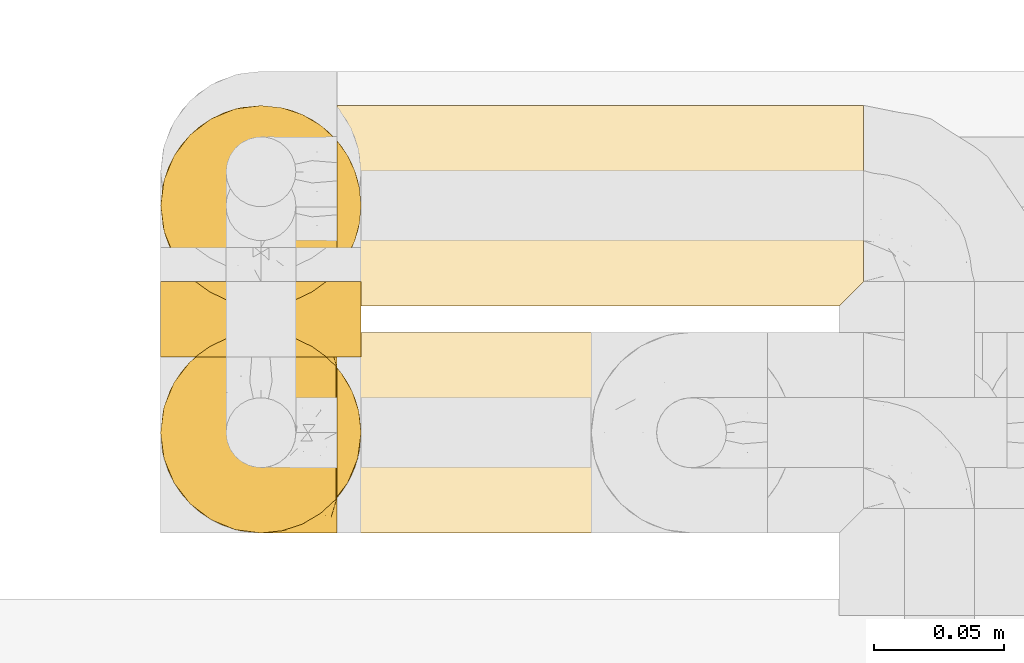
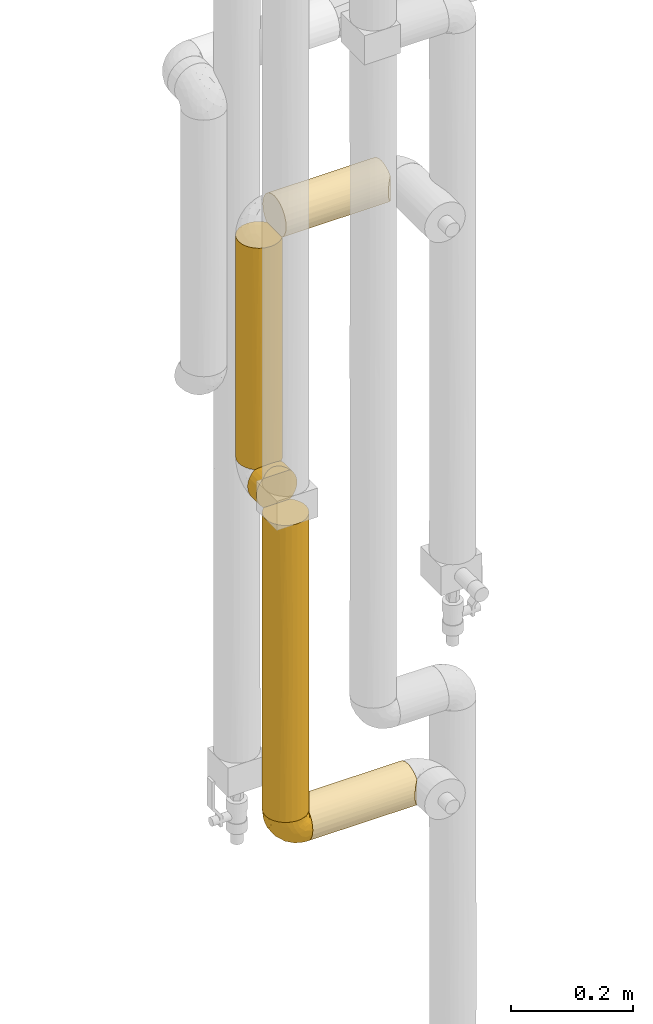
# One storey, part 326 of 827: 6 coverings.
"""IFC2X3 building model written with IfcOpenShell, lengths in millimetres."""

from ifc_helpers import new_model, entity, si_unit, converted_unit, derived_unit, direction, frame, origin, place, context, subcontext, project, spatial, faceted_brep, element, save


model = new_model("IFC2X3")

# Units and contexts
model_context = context("Model", 3, precision=0.01, world=origin(), true_north=direction((6.12303176911189e-17, 1.0)))
body_context = subcontext(model_context, "Body", "Model", "MODEL_VIEW")
ifc_project = project(units=[si_unit("LENGTHUNIT", "METRE", prefix="MILLI"), si_unit("AREAUNIT", "SQUARE_METRE"), si_unit("VOLUMEUNIT", "CUBIC_METRE"), converted_unit("PLANEANGLEUNIT", "DEGREE", entity("IfcRatioMeasure", 0.0174532925199433), si_unit("PLANEANGLEUNIT", "RADIAN"), dimensions=[0, 0, 0, 0, 0, 0, 0]), si_unit("MASSUNIT", "GRAM", prefix="KILO"), derived_unit("MASSDENSITYUNIT", [(si_unit("MASSUNIT", "GRAM", prefix="KILO"), 1), (si_unit("LENGTHUNIT", "METRE"), -3)]), derived_unit("MOMENTOFINERTIAUNIT", [(si_unit("LENGTHUNIT", "METRE"), 4)]), si_unit("TIMEUNIT", "SECOND"), si_unit("FREQUENCYUNIT", "HERTZ"), si_unit("THERMODYNAMICTEMPERATUREUNIT", "DEGREE_CELSIUS"), derived_unit("THERMALTRANSMITTANCEUNIT", [(si_unit("MASSUNIT", "GRAM", prefix="KILO"), 1), (si_unit("THERMODYNAMICTEMPERATUREUNIT", "KELVIN"), -1), (si_unit("TIMEUNIT", "SECOND"), -3)]), derived_unit("VOLUMETRICFLOWRATEUNIT", [(si_unit("LENGTHUNIT", "METRE"), 3), (si_unit("TIMEUNIT", "SECOND"), -1)]), derived_unit("MASSFLOWRATEUNIT", [(si_unit("MASSUNIT", "GRAM", prefix="KILO"), 1), (si_unit("TIMEUNIT", "SECOND"), -1)]), derived_unit("ROTATIONALFREQUENCYUNIT", [(si_unit("TIMEUNIT", "SECOND"), -1)]), si_unit("ELECTRICCURRENTUNIT", "AMPERE"), si_unit("ELECTRICVOLTAGEUNIT", "VOLT"), si_unit("POWERUNIT", "WATT"), si_unit("FORCEUNIT", "NEWTON", prefix="KILO"), si_unit("ILLUMINANCEUNIT", "LUX"), si_unit("LUMINOUSFLUXUNIT", "LUMEN"), si_unit("LUMINOUSINTENSITYUNIT", "CANDELA"), derived_unit("USERDEFINED", [(si_unit("MASSUNIT", "GRAM", prefix="KILO"), -1), (si_unit("LENGTHUNIT", "METRE"), -2), (si_unit("TIMEUNIT", "SECOND"), 3), (si_unit("LUMINOUSFLUXUNIT", "LUMEN"), 1)]), derived_unit("LINEARVELOCITYUNIT", [(si_unit("LENGTHUNIT", "METRE"), 1), (si_unit("TIMEUNIT", "SECOND"), -1)]), si_unit("PRESSUREUNIT", "PASCAL"), derived_unit("USERDEFINED", [(si_unit("LENGTHUNIT", "METRE"), -2), (si_unit("MASSUNIT", "GRAM", prefix="KILO"), 1), (si_unit("TIMEUNIT", "SECOND"), -2)]), derived_unit("LINEARFORCEUNIT", [(si_unit("MASSUNIT", "GRAM", prefix="KILO"), 1), (si_unit("LENGTHUNIT", "METRE"), 1), (si_unit("TIMEUNIT", "SECOND"), -2), (si_unit("LENGTHUNIT", "METRE"), -1)]), derived_unit("PLANARFORCEUNIT", [(si_unit("MASSUNIT", "GRAM", prefix="KILO"), 1), (si_unit("LENGTHUNIT", "METRE"), 1), (si_unit("TIMEUNIT", "SECOND"), -2), (si_unit("LENGTHUNIT", "METRE"), -2)])], contexts=[model_context])

# Site, building, storey
site_placement = place(None, origin())
site = spatial("IfcSite", under=ifc_project, at=site_placement, CompositionType="ELEMENT")
building_placement = place(site_placement, origin())
building = spatial("IfcBuilding", under=site, at=building_placement, CompositionType="ELEMENT")
storey_placement = place(building_placement, frame((0.0, 0.0, 28200.0)))
storey = spatial("IfcBuildingStorey", under=building, at=storey_placement, Name="08", CompositionType="ELEMENT", Elevation=28200.0)

# Coverings
covering_1_placement = place(storey_placement, frame((34485.39, 18294.92, 1087.5)))
element("IfcCovering", 1, at=covering_1_placement, inside=storey, Name=":ADSK_", ObjectType=":ADSK_", PredefinedType="INSULATION", context=body_context, shape_type="Brep", body=[
    faceted_brep([(73.25, 20.8, 593.5), (77.09, 30.06, 593.5), (78.4, 40.0, 593.5), (77.52, 48.16, 593.5), (74.93, 55.94, 593.5), (70.75, 62.99, 593.5), (65.17, 69.0, 593.5), (14.82, 69.0, 593.5), (9.24, 62.99, 593.5), (5.06, 55.94, 593.5), (2.47, 48.16, 593.5), (1.6, 40.0, 593.5), (2.9, 30.06, 593.5), (6.74, 20.8, 593.5), (12.84, 12.84, 593.5), (20.8, 6.74, 593.5), (30.06, 2.9, 593.5), (40.0, 1.6, 593.5), (49.93, 2.9, 593.5), (59.2, 6.74, 593.5), (67.15, 12.84, 593.5), (69.1, 14.94, 1.6), (63.08, 9.31, 1.6), (56.01, 5.09, 1.6), (48.2, 2.48, 1.6), (40.0, 1.6, 1.6), (30.06, 2.9, 1.6), (20.8, 6.74, 1.6), (12.84, 12.84, 1.6), (6.74, 20.8, 1.6), (2.9, 30.06, 1.6), (1.6, 40.0, 1.6), (2.9, 49.93, 1.6), (6.74, 59.2, 1.6), (12.84, 67.15, 1.6), (20.8, 73.25, 1.6), (30.06, 77.09, 1.6), (40.0, 78.4, 1.6), (48.2, 77.51, 1.6), (56.01, 74.9, 1.6), (63.08, 70.68, 1.6), (69.1, 65.05, 1.6), (77.79, 46.78, 10.29), (76.0, 53.36, 8.5), (77.01, 50.2, 296.29), (74.59, 56.67, 378.86), (73.07, 59.51, 5.57), (71.09, 62.53, 290.54), (50.25, 77.0, 298.79), (53.43, 75.97, 586.52), (56.68, 74.58, 392.52), (78.4, 40.0, 302.2), (78.4, 40.0, 227.27), (78.4, 40.0, 10.9), (62.64, 71.01, 304.65), (57.7, 74.07, 194.68), (40.0, 78.4, 292.85), (46.82, 77.78, 584.71), (59.61, 73.01, 589.48), (40.0, 78.4, 367.72), (40.0, 78.4, 584.1), (29.74, 77.0, 301.9), (11.64, 65.89, 381.54), (17.34, 71.0, 292.9), (23.33, 74.59, 205.22), (6.96, 59.58, 309.24), (33.17, 77.78, 584.71), (26.56, 75.97, 586.52), (20.38, 73.01, 589.48), (2.89, 49.87, 299.72), (1.6, 40.0, 377.12), (2.35, 32.42, 385.18), (4.52, 25.3, 339.18), (32.5, 2.33, 374.62), (25.3, 4.52, 297.55), (9.53, 16.62, 297.55), (16.62, 9.53, 339.18), (40.0, 1.6, 297.55), (40.0, 1.6, 217.97), (49.87, 2.89, 295.47), (59.66, 7.01, 285.81), (65.97, 11.72, 213.92), (71.08, 17.45, 301.5), (74.63, 23.42, 391.28), (73.07, 20.48, 5.57), (76.0, 26.63, 8.5), (77.02, 29.79, 293.21), (77.79, 33.21, 10.29)], [[[0, 1, 2, 3, 4, 5, 6, 7, 8, 9, 10, 11, 12, 13, 14, 15, 16, 17, 18, 19, 20]], [[21, 22, 23, 24, 25, 26, 27, 28, 29, 30, 31, 32, 33, 34, 35, 36, 37, 38, 39, 40, 41]], [[42, 43, 44]], [[5, 4, 45]], [[46, 41, 47]], [[48, 49, 50]], [[43, 45, 44]], [[45, 43, 46]], [[3, 51, 44]], [[51, 42, 44]], [[3, 44, 45]], [[42, 51, 52, 53]], [[47, 54, 6]], [[3, 45, 4]], [[51, 3, 2]], [[6, 5, 47]], [[55, 48, 50]], [[56, 38, 37]], [[39, 38, 48]], [[40, 55, 54]], [[48, 55, 39]], [[48, 56, 57]], [[55, 40, 39]], [[58, 6, 54]], [[46, 47, 45]], [[57, 49, 48]], [[38, 56, 48]], [[41, 40, 54]], [[50, 58, 54]], [[58, 50, 49]], [[55, 50, 54]], [[41, 54, 47]], [[57, 56, 59, 60]], [[5, 45, 47]], [[61, 59, 56, 37]], [[61, 37, 36]], [[34, 62, 63]], [[35, 63, 64]], [[34, 65, 62]], [[66, 61, 67]], [[66, 60, 59]], [[64, 67, 61]], [[59, 61, 66]], [[35, 34, 63]], [[63, 7, 68]], [[64, 68, 67]], [[34, 33, 65]], [[36, 64, 61]], [[69, 32, 31]], [[33, 69, 65]], [[68, 64, 63]], [[70, 11, 10]], [[9, 65, 69]], [[8, 65, 9]], [[69, 33, 32]], [[65, 8, 62]], [[70, 10, 69]], [[70, 69, 31]], [[9, 69, 10]], [[7, 63, 62]], [[7, 62, 8]], [[36, 35, 64]], [[71, 30, 72]], [[26, 73, 74]], [[71, 11, 70, 31]], [[72, 75, 13]], [[75, 72, 29]], [[71, 31, 30]], [[28, 75, 29]], [[75, 14, 13]], [[13, 12, 72]], [[27, 74, 76]], [[17, 73, 77]], [[74, 27, 26]], [[74, 15, 76]], [[28, 76, 75]], [[26, 25, 78, 77]], [[14, 75, 76]], [[27, 76, 28]], [[71, 72, 12]], [[15, 14, 76]], [[74, 73, 16]], [[15, 74, 16]], [[29, 72, 30]], [[77, 73, 26]], [[11, 71, 12]], [[73, 17, 16]], [[78, 24, 79]], [[80, 22, 81]], [[21, 81, 22]], [[20, 81, 82]], [[80, 23, 22]], [[83, 84, 85]], [[24, 78, 25]], [[23, 80, 79]], [[17, 79, 18]], [[20, 19, 80]], [[1, 0, 83]], [[82, 81, 21]], [[83, 85, 86]], [[20, 80, 81]], [[87, 86, 85]], [[0, 20, 82]], [[87, 53, 52]], [[52, 86, 87]], [[79, 19, 18]], [[83, 0, 82]], [[19, 79, 80]], [[2, 1, 86]], [[86, 52, 51, 2]], [[23, 79, 24]], [[84, 83, 82]], [[84, 82, 21]], [[1, 83, 86]], [[79, 17, 77, 78]], [[58, 49, 57, 60, 66, 67, 68, 7, 6]], [[41, 46, 43, 42, 53, 87, 85, 84, 21]]]),
])
covering_2_placement = place(storey_placement, frame((34552.89, 18294.92, 1020.0)))
element("IfcCovering", 2, at=covering_2_placement, inside=storey, Name=":ADSK_", ObjectType=":ADSK_", PredefinedType="INSULATION", context=body_context, shape_type="Brep", body=[
    faceted_brep([(1.6, 20.8, 6.74), (1.6, 12.84, 12.84), (1.6, 6.74, 20.8), (1.6, 2.9, 30.06), (1.6, 1.6, 40.0), (1.6, 2.48, 48.2), (1.6, 5.09, 56.01), (1.6, 9.31, 63.08), (1.6, 14.94, 69.1), (1.6, 65.05, 69.1), (1.6, 70.68, 63.08), (1.6, 74.9, 56.01), (1.6, 77.51, 48.2), (1.6, 78.4, 40.0), (1.6, 77.09, 30.06), (1.6, 73.25, 20.8), (1.6, 67.15, 12.84), (1.6, 59.2, 6.74), (1.6, 49.93, 2.9), (1.6, 40.0, 1.6), (1.6, 30.06, 2.9), (203.4, 10.9, 14.94), (203.4, 16.91, 9.31), (203.4, 23.98, 5.09), (203.4, 31.79, 2.48), (203.4, 40.0, 1.6), (203.4, 49.93, 2.9), (203.4, 59.2, 6.74), (203.4, 67.15, 12.84), (203.4, 73.25, 20.8), (203.4, 77.09, 30.06), (203.4, 78.4, 40.0), (203.4, 77.09, 49.93), (203.4, 73.25, 59.2), (203.4, 67.15, 67.15), (203.4, 59.2, 73.25), (203.4, 49.93, 77.09), (203.4, 40.0, 78.4), (203.4, 31.79, 77.51), (203.4, 23.98, 74.9), (203.4, 16.91, 70.68), (203.4, 10.9, 65.05), (199.42, 6.92, 20.48), (196.5, 4.0, 26.63), (194.7, 2.2, 33.21), (194.1, 1.6, 40.0), (194.7, 2.2, 46.78), (196.5, 4.0, 53.36), (199.42, 6.92, 59.51), (5.57, 20.48, 73.07), (8.5, 26.63, 76.0), (10.29, 33.21, 77.79), (10.9, 40.0, 78.4), (10.29, 46.78, 77.79), (8.5, 53.36, 76.0), (5.57, 59.51, 73.07)], [[[0, 1, 2, 3, 4, 5, 6, 7, 8, 9, 10, 11, 12, 13, 14, 15, 16, 17, 18, 19, 20]], [[21, 22, 23, 24, 25, 26, 27, 28, 29, 30, 31, 32, 33, 34, 35, 36, 37, 38, 39, 40, 41]], [[30, 29, 15, 14]], [[31, 30, 14, 13]], [[29, 28, 16, 15]], [[18, 17, 27, 26]], [[19, 18, 26, 25]], [[28, 27, 17, 16]], [[19, 25, 24]], [[20, 24, 23]], [[0, 23, 22]], [[19, 24, 20]], [[20, 23, 0]], [[22, 1, 0]], [[22, 21, 1]], [[21, 42, 2]], [[43, 44, 3]], [[42, 43, 2]], [[2, 43, 3]], [[4, 3, 44]], [[45, 4, 44]], [[21, 2, 1]], [[46, 47, 5]], [[48, 41, 7]], [[47, 48, 6]], [[45, 46, 4]], [[5, 4, 46]], [[47, 6, 5]], [[48, 7, 6]], [[41, 8, 7]], [[49, 40, 39]], [[50, 39, 38]], [[51, 38, 37]], [[49, 8, 40]], [[51, 50, 38]], [[52, 51, 37]], [[49, 39, 50]], [[40, 8, 41]], [[53, 52, 37]], [[53, 37, 36]], [[54, 36, 35]], [[54, 53, 36]], [[9, 55, 35]], [[54, 35, 55]], [[35, 34, 9]], [[10, 34, 33]], [[11, 33, 32]], [[12, 32, 31]], [[10, 33, 11]], [[11, 32, 12]], [[31, 13, 12]], [[34, 10, 9]], [[8, 49, 50, 51, 52, 53, 54, 55, 9]], [[44, 43, 42, 21, 41, 48, 47, 46, 45]]]),
])
covering_3_placement = place(storey_placement, frame((34485.34, 18294.87, 1019.95)))
element("IfcCovering", 3, at=covering_3_placement, inside=storey, Name=":ADSK_", ObjectType=":ADSK_", PredefinedType="INSULATION", context=body_context, shape_type="Brep", body=[
    faceted_brep([(69.15, 2.46, 48.13), (69.15, 1.6, 40.05), (69.15, 2.56, 31.49), (69.15, 5.41, 23.36), (69.15, 9.99, 16.07), (69.15, 16.08, 9.98), (69.15, 23.37, 5.4), (69.15, 31.49, 2.56), (69.15, 40.05, 1.6), (69.15, 48.61, 2.56), (69.15, 56.73, 5.41), (69.15, 64.02, 9.99), (69.15, 70.11, 16.08), (69.15, 74.69, 23.37), (69.15, 77.53, 31.49), (69.15, 78.5, 40.05), (69.15, 77.63, 48.15), (69.15, 75.08, 55.88), (69.15, 70.97, 62.9), (69.15, 65.47, 68.89), (69.15, 63.27, 68.89), (69.15, 61.53, 68.89), (69.15, 59.57, 68.89), (69.15, 57.6, 68.89), (69.15, 55.63, 68.89), (69.15, 53.67, 68.89), (69.15, 51.7, 68.89), (69.15, 49.73, 68.89), (69.15, 47.54, 68.89), (69.15, 45.34, 68.89), (69.15, 43.15, 68.89), (69.15, 40.96, 68.89), (69.15, 38.76, 68.89), (69.15, 36.57, 68.89), (69.15, 34.37, 68.89), (69.15, 32.18, 68.89), (69.15, 29.98, 68.89), (69.15, 27.79, 68.89), (69.15, 25.6, 68.89), (69.15, 23.4, 68.89), (69.15, 21.21, 68.89), (69.15, 19.01, 68.89), (69.15, 16.82, 68.89), (69.15, 14.62, 68.89), (69.15, 9.12, 62.89), (69.15, 5.0, 55.86), (68.89, 65.47, 69.15), (62.89, 70.97, 69.15), (55.87, 75.09, 69.15), (48.14, 77.63, 69.15), (40.05, 78.5, 69.15), (30.09, 77.19, 69.15), (20.82, 73.34, 69.15), (12.86, 67.23, 69.15), (6.75, 59.27, 69.15), (2.91, 50.0, 69.15), (1.6, 40.05, 69.15), (2.91, 30.09, 69.15), (6.75, 20.82, 69.15), (12.86, 12.86, 69.15), (20.82, 6.75, 69.15), (30.09, 2.91, 69.15), (40.05, 1.6, 69.15), (48.14, 2.46, 69.15), (55.87, 5.0, 69.15), (62.89, 9.12, 69.15), (68.89, 14.62, 69.15), (68.89, 16.82, 69.15), (68.89, 17.8, 69.15), (68.89, 19.39, 69.15), (68.89, 20.98, 69.15), (68.89, 22.57, 69.15), (68.89, 24.16, 69.15), (68.89, 25.75, 69.15), (68.89, 27.33, 69.15), (68.89, 28.92, 69.15), (68.89, 30.51, 69.15), (68.89, 32.1, 69.15), (68.89, 33.69, 69.15), (68.89, 35.28, 69.15), (68.89, 36.87, 69.15), (68.89, 38.46, 69.15), (68.89, 40.05, 69.15), (68.89, 41.63, 69.15), (68.89, 43.22, 69.15), (68.89, 44.81, 69.15), (68.89, 46.4, 69.15), (68.89, 47.99, 69.15), (68.89, 49.58, 69.15), (68.89, 51.17, 69.15), (68.89, 52.76, 69.15), (68.89, 54.72, 69.15), (68.89, 56.69, 69.15), (68.89, 58.88, 69.15), (68.89, 61.08, 69.15), (68.89, 63.27, 69.15), (68.97, 37.77, 68.96), (68.96, 36.07, 68.97), (68.97, 32.96, 68.97), (68.97, 31.36, 68.97), (68.98, 56.52, 68.95), (68.97, 54.96, 68.96), (68.96, 18.75, 68.98), (68.96, 58.07, 68.97), (68.96, 50.37, 68.97), (68.96, 23.36, 68.98), (68.96, 24.95, 68.97), (68.96, 42.43, 68.97), (69.0, 15.97, 68.94), (68.96, 51.96, 68.98), (68.96, 53.47, 68.98), (68.97, 48.63, 68.96), (68.96, 63.93, 68.97), (68.96, 40.93, 68.98), (68.96, 29.72, 68.98), (68.97, 62.4, 68.97), (68.97, 60.92, 68.96), (68.97, 17.31, 68.97), (68.96, 21.74, 68.97), (68.96, 34.56, 68.98), (68.97, 20.18, 68.96), (68.97, 14.62, 68.97), (69.02, 14.62, 68.94), (69.08, 14.62, 68.92), (68.97, 65.47, 68.97), (68.94, 65.47, 69.02), (68.92, 65.47, 69.08), (68.96, 59.5, 68.98), (68.96, 47.1, 68.97), (68.95, 45.61, 68.98), (68.96, 28.18, 68.97), (68.92, 14.62, 69.08), (68.94, 14.62, 69.02), (68.98, 26.61, 68.96), (69.08, 65.47, 68.92), (69.02, 65.47, 68.94), (68.96, 39.32, 68.97), (68.97, 44.12, 68.96), (61.33, 72.26, 67.02), (53.1, 76.57, 63.33), (63.33, 71.77, 64.61), (49.27, 78.5, 49.27), (55.53, 77.9, 51.4), (54.6, 78.5, 43.94), (41.99, 78.5, 61.87), (57.07, 75.52, 61.54), (57.95, 76.13, 57.95), (51.56, 77.81, 56.12), (61.7, 72.4, 65.41), (63.33, 76.56, 53.1), (65.0, 71.77, 63.04), (67.02, 72.25, 61.33), (61.87, 78.5, 41.99), (43.94, 78.5, 54.6), (61.21, 75.75, 56.6), (63.4, 78.5, 41.58), (26.0, 75.57, 61.54), (58.71, 76.34, 28.67), (33.48, 77.64, 58.75), (14.17, 63.45, 46.12), (18.43, 70.55, 55.56), (24.87, 71.02, 42.09), (45.01, 66.15, 17.15), (44.4, 60.51, 12.68), (35.53, 63.72, 20.17), (28.67, 75.57, 52.38), (49.25, 72.61, 23.76), (48.22, 76.83, 34.7), (59.72, 72.61, 20.5), (55.1, 67.24, 14.64), (5.25, 47.19, 49.4), (6.75, 54.76, 52.34), (10.47, 63.45, 58.67), (52.82, 52.75, 5.82), (16.81, 53.89, 30.64), (17.38, 46.73, 26.66), (10.56, 48.67, 37.53), (11.2, 55.34, 41.11), (21.38, 40.05, 21.38), (33.11, 50.46, 13.72), (43.3, 40.05, 6.74), (32.34, 40.05, 14.06), (44.72, 77.74, 41.77), (36.52, 77.66, 51.58), (34.15, 57.43, 16.28), (55.54, 40.05, 4.3), (57.42, 60.51, 8.62), (25.49, 60.1, 25.26), (23.96, 51.88, 21.47), (34.84, 72.59, 33.37), (36.87, 76.05, 41.35), (4.3, 40.05, 55.54), (20.65, 63.95, 35.17), (29.66, 67.24, 29.04), (39.6, 69.62, 24.34), (42.55, 73.6, 29.33), (6.74, 40.05, 43.3), (14.06, 40.05, 32.34), (5.28, 32.72, 49.41), (63.4, 1.6, 41.58), (58.71, 3.75, 28.66), (33.13, 29.63, 13.7), (18.52, 27.18, 27.85), (52.83, 27.35, 5.82), (44.4, 19.59, 12.67), (42.69, 12.86, 19.45), (55.1, 12.86, 14.63), (49.26, 7.49, 23.75), (20.72, 9.54, 48.85), (11.46, 16.64, 54.13), (17.69, 17.48, 37.84), (35.35, 2.33, 55.15), (43.94, 1.6, 54.6), (41.99, 1.6, 61.87), (29.34, 8.17, 37.91), (30.26, 4.3, 50.18), (4.93, 26.94, 57.58), (29.72, 20.75, 20.83), (17.46, 9.54, 59.91), (26.84, 4.52, 57.75), (59.73, 7.49, 20.49), (61.87, 1.6, 41.99), (54.6, 1.6, 43.94), (57.43, 19.59, 8.61), (48.2, 3.27, 34.7), (43.06, 2.45, 42.64), (49.27, 1.6, 49.27), (10.94, 31.21, 36.94), (8.92, 25.33, 45.72), (33.44, 2.29, 62.29), (29.67, 12.86, 29.01), (38.5, 6.89, 31.47), (39.06, 2.23, 49.29), (23.35, 12.43, 37.18), (34.97, 4.1, 43.45), (53.1, 3.53, 63.33), (59.68, 6.88, 67.23), (62.19, 8.16, 66.07), (64.11, 9.02, 65.22), (57.97, 5.0, 61.99), (57.95, 3.96, 57.95), (63.33, 3.52, 53.09), (51.77, 2.4, 56.84), (67.02, 7.83, 61.33), (64.98, 8.32, 63.06), (55.53, 2.19, 51.41), (61.22, 4.34, 56.61)], [[[0, 1, 2, 3, 4, 5, 6, 7, 8, 9, 10, 11, 12, 13, 14, 15, 16, 17, 18, 19, 20, 21, 22, 23, 24, 25, 26, 27, 28, 29, 30, 31, 32, 33, 34, 35, 36, 37, 38, 39, 40, 41, 42, 43, 44, 45]], [[46, 47, 48, 49, 50, 51, 52, 53, 54, 55, 56, 57, 58, 59, 60, 61, 62, 63, 64, 65, 66, 67, 68, 69, 70, 71, 72, 73, 74, 75, 76, 77, 78, 79, 80, 81, 82, 83, 84, 85, 86, 87, 88, 89, 90, 91, 92, 93, 94, 95]], [[96, 97, 33]], [[98, 77, 99]], [[100, 101, 24]], [[69, 68, 102]], [[23, 22, 103]], [[27, 26, 104]], [[23, 103, 100]], [[72, 105, 106]], [[84, 83, 107]], [[89, 88, 104]], [[108, 67, 66]], [[109, 110, 90]], [[111, 28, 27]], [[112, 20, 19]], [[82, 113, 83]], [[109, 26, 25]], [[114, 76, 75]], [[105, 39, 106]], [[104, 111, 27]], [[21, 115, 116]], [[97, 96, 80]], [[67, 108, 117]], [[105, 71, 118]], [[34, 97, 119]], [[102, 120, 69]], [[108, 121, 122, 123, 43]], [[112, 95, 115]], [[20, 115, 21]], [[94, 116, 115]], [[117, 68, 67]], [[41, 117, 42]], [[112, 124, 125, 126, 46]], [[20, 112, 115]], [[70, 120, 118]], [[42, 117, 108]], [[120, 41, 40]], [[120, 40, 118]], [[120, 70, 69]], [[116, 94, 127]], [[128, 86, 129]], [[117, 41, 102]], [[74, 130, 75]], [[99, 36, 35]], [[115, 95, 94]], [[42, 108, 43]], [[108, 66, 131, 132, 121]], [[105, 72, 71]], [[118, 40, 39]], [[71, 70, 118]], [[38, 106, 39]], [[39, 105, 118]], [[38, 133, 106]], [[74, 73, 133]], [[106, 133, 73]], [[99, 114, 36]], [[133, 38, 37]], [[73, 72, 106]], [[95, 112, 46]], [[112, 19, 134, 135, 124]], [[130, 114, 75]], [[99, 76, 114]], [[114, 130, 36]], [[37, 36, 130]], [[78, 77, 98]], [[98, 119, 78]], [[130, 133, 37]], [[133, 130, 74]], [[79, 97, 80]], [[98, 99, 35]], [[98, 35, 34]], [[77, 76, 99]], [[97, 79, 119]], [[136, 96, 32]], [[33, 97, 34]], [[136, 32, 31]], [[81, 80, 96]], [[32, 96, 33]], [[34, 119, 98]], [[119, 79, 78]], [[96, 136, 81]], [[82, 81, 136]], [[113, 107, 83]], [[84, 107, 137]], [[107, 30, 137]], [[113, 31, 107]], [[30, 107, 31]], [[85, 84, 137]], [[137, 30, 29]], [[113, 136, 31]], [[136, 113, 82]], [[109, 89, 104]], [[86, 85, 129]], [[89, 109, 90]], [[111, 87, 128]], [[29, 129, 137]], [[88, 111, 104]], [[28, 111, 128]], [[25, 110, 109]], [[26, 109, 104]], [[110, 91, 90]], [[100, 92, 101]], [[110, 25, 101]], [[91, 110, 101]], [[116, 22, 21]], [[111, 88, 87]], [[127, 103, 22]], [[28, 128, 29]], [[86, 128, 87]], [[128, 129, 29]], [[137, 129, 85]], [[120, 102, 41]], [[117, 102, 68]], [[91, 101, 92]], [[24, 101, 25]], [[93, 92, 103]], [[100, 24, 23]], [[100, 103, 92]], [[127, 93, 103]], [[93, 127, 94]], [[116, 127, 22]], [[126, 138, 47]], [[48, 138, 139]], [[140, 125, 124]], [[141, 142, 143]], [[144, 49, 139]], [[145, 140, 146]], [[48, 139, 49]], [[139, 145, 147]], [[144, 50, 49]], [[126, 125, 148]], [[17, 16, 149]], [[150, 146, 140]], [[148, 140, 145]], [[151, 150, 135]], [[151, 17, 149]], [[19, 18, 134]], [[16, 152, 149]], [[124, 150, 140]], [[141, 147, 142]], [[17, 151, 18]], [[18, 151, 134]], [[47, 46, 126]], [[139, 153, 144]], [[138, 48, 47]], [[125, 140, 148]], [[135, 134, 151]], [[146, 154, 142]], [[145, 146, 147]], [[148, 139, 138]], [[147, 141, 153]], [[147, 146, 142]], [[139, 147, 153]], [[139, 148, 145]], [[148, 138, 126]], [[154, 146, 150]], [[149, 143, 142]], [[151, 154, 150]], [[149, 142, 154]], [[16, 15, 155, 152]], [[152, 143, 149]], [[151, 149, 154]], [[150, 124, 135]], [[51, 156, 52]], [[155, 14, 157]], [[50, 144, 158]], [[159, 160, 161]], [[162, 163, 164]], [[158, 165, 156]], [[157, 166, 167]], [[166, 168, 169]], [[170, 55, 171]], [[161, 160, 165]], [[172, 54, 53]], [[160, 53, 52]], [[173, 10, 9]], [[54, 172, 171]], [[174, 175, 176]], [[170, 177, 176]], [[167, 143, 157]], [[178, 179, 180, 181]], [[157, 14, 13]], [[141, 182, 183]], [[160, 52, 156]], [[173, 179, 184]], [[11, 169, 12]], [[173, 9, 185]], [[155, 15, 14]], [[11, 10, 186]], [[162, 169, 163]], [[187, 184, 188]], [[180, 173, 185]], [[13, 168, 157]], [[54, 171, 55]], [[186, 173, 163]], [[157, 143, 152, 155]], [[189, 161, 190]], [[179, 173, 180]], [[12, 168, 13]], [[186, 169, 11]], [[187, 164, 184]], [[144, 183, 158]], [[172, 160, 159]], [[177, 174, 176]], [[55, 170, 191]], [[187, 192, 193]], [[183, 182, 190]], [[166, 194, 195]], [[167, 190, 182]], [[9, 8, 185]], [[173, 186, 10]], [[169, 186, 163]], [[169, 168, 12]], [[157, 168, 166]], [[190, 161, 165]], [[161, 193, 192]], [[183, 165, 158]], [[194, 189, 195]], [[191, 170, 196]], [[191, 56, 55]], [[175, 178, 197]], [[197, 196, 176]], [[170, 176, 196]], [[188, 175, 174]], [[197, 176, 175]], [[177, 170, 171]], [[171, 159, 177]], [[192, 177, 159]], [[187, 188, 174]], [[188, 179, 178]], [[174, 177, 192]], [[164, 187, 193]], [[174, 192, 187]], [[161, 192, 159]], [[194, 164, 193]], [[184, 164, 163]], [[189, 194, 193]], [[162, 166, 169]], [[161, 189, 193]], [[195, 190, 167]], [[173, 184, 163]], [[184, 179, 188]], [[164, 194, 162]], [[166, 162, 194]], [[190, 195, 189]], [[167, 182, 143]], [[167, 166, 195]], [[160, 172, 53]], [[171, 172, 159]], [[51, 50, 158]], [[160, 156, 165]], [[51, 158, 156]], [[183, 144, 153]], [[141, 183, 153]], [[190, 165, 183]], [[178, 175, 188]], [[143, 182, 141]], [[198, 191, 196]], [[2, 199, 200]], [[178, 201, 202]], [[201, 203, 204]], [[205, 206, 207]], [[57, 56, 191]], [[7, 185, 8]], [[208, 209, 210]], [[211, 212, 213]], [[208, 214, 215]], [[216, 209, 58]], [[201, 217, 202]], [[59, 218, 60]], [[60, 218, 219]], [[201, 178, 181, 180]], [[4, 3, 220]], [[201, 180, 203]], [[200, 199, 221, 222]], [[203, 185, 7]], [[6, 203, 7]], [[5, 4, 206]], [[217, 210, 202]], [[58, 209, 59]], [[6, 223, 203]], [[207, 220, 200]], [[204, 223, 206]], [[205, 204, 206]], [[207, 200, 224]], [[200, 222, 224]], [[206, 223, 5]], [[225, 222, 226]], [[220, 206, 4]], [[60, 219, 61]], [[57, 198, 216]], [[227, 202, 228]], [[6, 5, 223]], [[2, 1, 199]], [[3, 2, 200]], [[219, 211, 229]], [[230, 231, 214]], [[231, 207, 224]], [[210, 209, 228]], [[218, 209, 208]], [[226, 232, 225]], [[231, 230, 205]], [[202, 210, 228]], [[233, 230, 214]], [[227, 228, 198]], [[201, 204, 217]], [[211, 232, 212]], [[180, 185, 203]], [[61, 229, 62]], [[203, 223, 204]], [[200, 220, 3]], [[206, 220, 207]], [[225, 231, 224]], [[232, 226, 212]], [[214, 231, 234]], [[197, 227, 196]], [[191, 198, 57]], [[198, 228, 216]], [[202, 197, 178]], [[196, 227, 198]], [[197, 202, 227]], [[209, 216, 228]], [[58, 57, 216]], [[229, 211, 213]], [[215, 211, 219]], [[205, 217, 204]], [[210, 217, 230]], [[62, 229, 213]], [[219, 229, 61]], [[231, 205, 207]], [[217, 205, 230]], [[215, 214, 234]], [[233, 208, 210]], [[209, 218, 59]], [[219, 218, 208]], [[208, 215, 219]], [[232, 215, 234]], [[215, 232, 211]], [[232, 234, 225]], [[231, 225, 234]], [[222, 225, 224]], [[208, 233, 214]], [[210, 230, 233]], [[63, 213, 235]], [[213, 212, 235]], [[213, 63, 62]], [[236, 235, 237]], [[237, 132, 131]], [[235, 236, 64]], [[238, 239, 240]], [[63, 235, 64]], [[131, 66, 65]], [[236, 131, 65]], [[241, 221, 0]], [[236, 65, 64]], [[238, 121, 132]], [[45, 241, 0]], [[240, 239, 242]], [[44, 123, 243]], [[0, 221, 199, 1]], [[243, 122, 244]], [[226, 245, 242]], [[240, 242, 245]], [[121, 238, 244]], [[44, 43, 123]], [[132, 237, 238]], [[243, 45, 44]], [[131, 236, 237]], [[239, 238, 237]], [[244, 238, 240]], [[246, 240, 245]], [[246, 243, 244]], [[237, 235, 239]], [[242, 235, 212]], [[235, 242, 239]], [[222, 245, 226]], [[242, 212, 226]], [[222, 241, 245]], [[240, 246, 244]], [[245, 241, 246]], [[243, 246, 241]], [[241, 222, 221]], [[45, 243, 241]], [[122, 243, 123]], [[122, 121, 244]]]),
])
covering_4_placement = place(storey_placement, frame((34552.89, 18381.91, 2170.0)))
element("IfcCovering", 4, at=covering_4_placement, inside=storey, Name=":ADSK_", ObjectType=":ADSK_", PredefinedType="INSULATION", context=body_context, shape_type="Brep", body=[
    faceted_brep([(203.4, 59.2, 6.74), (203.4, 67.15, 12.84), (203.4, 73.25, 20.8), (203.4, 77.09, 30.06), (203.4, 78.4, 40.0), (203.4, 77.09, 49.93), (203.4, 73.25, 59.2), (203.4, 67.15, 67.15), (203.4, 59.2, 73.25), (203.4, 49.93, 77.09), (203.4, 40.0, 78.4), (203.4, 31.79, 77.51), (203.4, 23.98, 74.9), (203.4, 16.91, 70.68), (203.4, 10.9, 65.05), (203.4, 10.9, 14.94), (203.4, 16.91, 9.31), (203.4, 23.98, 5.09), (203.4, 31.79, 2.48), (203.4, 40.0, 1.6), (203.4, 49.93, 2.9), (1.6, 77.09, 49.93), (1.6, 78.4, 40.0), (1.6, 77.51, 31.79), (1.6, 74.9, 23.98), (1.6, 70.68, 16.91), (1.6, 65.05, 10.9), (1.6, 14.94, 10.9), (1.6, 9.31, 16.91), (1.6, 5.09, 23.98), (1.6, 2.48, 31.79), (1.6, 1.6, 40.0), (1.6, 2.9, 49.93), (1.6, 6.74, 59.2), (1.6, 12.84, 67.15), (1.6, 20.8, 73.25), (1.6, 30.06, 77.09), (1.6, 40.0, 78.4), (1.6, 49.93, 77.09), (1.6, 59.2, 73.25), (1.6, 67.15, 67.15), (1.6, 73.25, 59.2), (194.7, 2.2, 33.21), (196.5, 4.0, 26.63), (199.42, 6.92, 20.48), (194.1, 1.6, 40.0), (5.57, 20.48, 6.92), (8.5, 26.63, 4.0), (10.29, 33.21, 2.2), (10.9, 40.0, 1.6), (10.29, 46.78, 2.2), (8.5, 53.36, 4.0), (5.57, 59.51, 6.92), (196.5, 4.0, 53.36), (194.7, 2.2, 46.78), (199.42, 6.92, 59.51)], [[[0, 1, 2, 3, 4, 5, 6, 7, 8, 9, 10, 11, 12, 13, 14, 15, 16, 17, 18, 19, 20]], [[21, 22, 23, 24, 25, 26, 27, 28, 29, 30, 31, 32, 33, 34, 35, 36, 37, 38, 39, 40, 41]], [[31, 30, 42]], [[30, 29, 43]], [[44, 29, 28]], [[42, 45, 31]], [[44, 43, 29]], [[15, 44, 28]], [[42, 30, 43]], [[28, 27, 15]], [[27, 46, 16]], [[47, 48, 18]], [[46, 47, 17]], [[16, 46, 17]], [[48, 19, 18]], [[18, 17, 47]], [[19, 48, 49]], [[27, 16, 15]], [[50, 51, 20]], [[52, 26, 0]], [[51, 52, 0]], [[49, 50, 19]], [[19, 50, 20]], [[51, 0, 20]], [[26, 1, 0]], [[2, 25, 24]], [[3, 24, 23]], [[4, 23, 22]], [[1, 25, 2]], [[2, 24, 3]], [[23, 4, 3]], [[25, 1, 26]], [[5, 4, 22, 21]], [[6, 5, 21, 41]], [[41, 40, 7, 6]], [[9, 8, 39, 38]], [[10, 9, 38, 37]], [[40, 39, 8, 7]], [[11, 37, 36]], [[12, 36, 35]], [[13, 35, 34]], [[10, 37, 11]], [[11, 36, 12]], [[35, 13, 12]], [[34, 14, 13]], [[53, 33, 32]], [[32, 31, 54]], [[45, 54, 31]], [[55, 14, 33]], [[54, 53, 32]], [[55, 33, 53]], [[33, 14, 34]], [[45, 42, 43, 44, 15, 14, 55, 53, 54]], [[26, 52, 51, 50, 49, 48, 47, 46, 27]]]),
])
covering_5_placement = place(storey_placement, frame((34485.39, 18381.91, 1737.5)))
element("IfcCovering", 5, at=covering_5_placement, inside=storey, Name=":ADSK_", ObjectType=":ADSK_", PredefinedType="INSULATION", context=body_context, shape_type="Brep", body=[
    faceted_brep([(56.01, 5.09, 443.4), (63.08, 9.31, 443.4), (69.1, 14.94, 443.4), (69.1, 65.05, 443.4), (63.08, 70.68, 443.4), (56.01, 74.9, 443.4), (48.2, 77.51, 443.4), (40.0, 78.4, 443.4), (30.06, 77.09, 443.4), (20.8, 73.25, 443.4), (12.84, 67.15, 443.4), (6.74, 59.2, 443.4), (2.9, 49.93, 443.4), (1.6, 40.0, 443.4), (2.9, 30.06, 443.4), (6.74, 20.8, 443.4), (12.84, 12.84, 443.4), (20.8, 6.74, 443.4), (30.06, 2.9, 443.4), (40.0, 1.6, 443.4), (48.2, 2.48, 443.4), (73.25, 59.2, 1.6), (77.09, 49.93, 1.6), (78.4, 40.0, 1.6), (77.51, 31.79, 1.6), (74.9, 23.98, 1.6), (70.68, 16.91, 1.6), (65.05, 10.9, 1.6), (14.94, 10.9, 1.6), (9.31, 16.91, 1.6), (5.09, 23.98, 1.6), (2.48, 31.79, 1.6), (1.6, 40.0, 1.6), (2.9, 49.93, 1.6), (6.74, 59.2, 1.6), (12.84, 67.15, 1.6), (20.8, 73.25, 1.6), (30.06, 77.09, 1.6), (40.0, 78.4, 1.6), (49.93, 77.09, 1.6), (59.2, 73.25, 1.6), (67.15, 67.15, 1.6), (77.02, 29.82, 225.77), (77.79, 33.21, 434.7), (76.0, 26.63, 436.5), (62.49, 8.87, 212.99), (59.51, 6.92, 5.57), (50.17, 2.97, 219.22), (53.36, 4.0, 8.5), (56.58, 5.36, 182.06), (40.0, 1.6, 227.27), (46.78, 2.2, 10.29), (40.0, 1.6, 10.9), (78.4, 40.0, 217.72), (71.12, 17.5, 232.0), (74.63, 23.41, 262.93), (78.4, 40.0, 434.1), (73.07, 20.48, 439.42), (77.02, 50.17, 229.68), (74.64, 56.56, 184.42), (71.11, 62.5, 217.9), (65.94, 68.31, 244.29), (77.79, 46.78, 434.7), (76.0, 53.36, 436.5), (73.07, 59.51, 439.42), (59.66, 72.98, 238.22), (52.17, 76.41, 233.35), (40.0, 78.4, 227.02), (32.5, 77.66, 238.05), (25.3, 75.47, 222.5), (2.33, 47.48, 237.84), (4.52, 54.69, 222.5), (16.62, 70.46, 222.5), (9.53, 63.37, 222.5), (1.6, 40.0, 217.97), (3.58, 27.82, 211.64), (7.01, 20.33, 206.77), (20.48, 6.92, 5.57), (23.43, 5.35, 260.57), (17.49, 8.88, 227.09), (29.82, 2.97, 215.31), (33.21, 2.2, 10.29), (11.69, 14.05, 200.7), (26.63, 4.0, 8.5)], [[[0, 1, 2, 3, 4, 5, 6, 7, 8, 9, 10, 11, 12, 13, 14, 15, 16, 17, 18, 19, 20]], [[21, 22, 23, 24, 25, 26, 27, 28, 29, 30, 31, 32, 33, 34, 35, 36, 37, 38, 39, 40, 41]], [[42, 43, 44]], [[0, 45, 1]], [[46, 27, 45]], [[47, 48, 49]], [[19, 50, 20]], [[45, 49, 46]], [[50, 47, 20]], [[50, 51, 47]], [[52, 51, 50]], [[0, 20, 47]], [[53, 42, 24]], [[45, 54, 2]], [[49, 0, 47]], [[42, 44, 55]], [[2, 1, 45]], [[55, 25, 42]], [[25, 24, 42]], [[25, 55, 54]], [[53, 56, 43]], [[25, 54, 26]], [[57, 2, 54]], [[47, 51, 48]], [[27, 26, 54]], [[53, 43, 42]], [[23, 53, 24]], [[55, 57, 54]], [[0, 49, 45]], [[57, 55, 44]], [[27, 54, 45]], [[46, 49, 48]], [[53, 22, 58]], [[22, 53, 23]], [[22, 59, 58]], [[21, 60, 59]], [[40, 61, 41]], [[62, 58, 63]], [[62, 56, 53]], [[59, 63, 58]], [[59, 64, 63]], [[21, 41, 60]], [[60, 3, 64]], [[53, 58, 62]], [[40, 65, 61]], [[41, 61, 60]], [[40, 39, 66]], [[66, 65, 40]], [[3, 61, 4]], [[67, 7, 6]], [[66, 6, 5]], [[4, 65, 5]], [[67, 66, 39]], [[66, 5, 65]], [[67, 6, 66]], [[38, 67, 39]], [[65, 4, 61]], [[3, 60, 61]], [[64, 59, 60]], [[59, 22, 21]], [[68, 37, 69]], [[33, 70, 71]], [[68, 7, 67, 38]], [[69, 37, 36]], [[68, 38, 37]], [[8, 69, 9]], [[69, 8, 68]], [[72, 10, 9]], [[72, 69, 36]], [[73, 72, 35]], [[13, 70, 32, 74]], [[71, 34, 33]], [[70, 12, 71]], [[13, 12, 70]], [[73, 11, 10]], [[71, 73, 34]], [[32, 70, 33]], [[71, 11, 73]], [[72, 73, 10]], [[35, 72, 36]], [[11, 71, 12]], [[34, 73, 35]], [[7, 68, 8]], [[69, 72, 9]], [[74, 31, 75]], [[75, 30, 76]], [[77, 78, 79]], [[18, 78, 80]], [[76, 30, 29]], [[50, 80, 81]], [[31, 74, 32]], [[75, 31, 30]], [[75, 15, 14]], [[15, 76, 82]], [[78, 18, 17]], [[79, 82, 28]], [[78, 83, 80]], [[15, 82, 16]], [[81, 80, 83]], [[17, 16, 79]], [[81, 52, 50]], [[83, 78, 77]], [[74, 75, 14]], [[78, 17, 79]], [[75, 76, 15]], [[50, 19, 18]], [[18, 80, 50]], [[76, 29, 82]], [[28, 82, 29]], [[77, 79, 28]], [[16, 82, 79]], [[13, 74, 14]], [[2, 57, 44, 43, 56, 62, 63, 64, 3]], [[46, 48, 51, 52, 81, 83, 77, 28, 27]]]),
])
covering_6_placement = place(storey_placement, frame((34485.39, 18362.32, 1670.0)))
element("IfcCovering", 6, at=covering_6_placement, inside=storey, Name=":ADSK_", ObjectType=":ADSK_", PredefinedType="INSULATION", context=body_context, shape_type="Brep", body=[
    faceted_brep([(5.06, 1.6, 24.05), (9.24, 1.6, 17.0), (14.82, 1.6, 11.0), (65.17, 1.6, 11.0), (70.75, 1.6, 17.0), (74.93, 1.6, 24.05), (77.52, 1.6, 31.83), (78.4, 1.6, 40.0), (77.52, 1.6, 48.16), (74.93, 1.6, 55.94), (70.75, 1.6, 62.99), (65.17, 1.6, 69.0), (14.82, 1.6, 69.0), (9.24, 1.6, 62.99), (5.06, 1.6, 55.94), (2.47, 1.6, 48.16), (1.6, 1.6, 40.0), (2.47, 1.6, 31.83), (40.0, 30.49, 1.6), (30.06, 30.49, 2.9), (20.8, 30.49, 6.74), (12.84, 30.49, 12.84), (6.74, 30.49, 20.8), (2.9, 30.49, 30.06), (1.6, 30.49, 40.0), (2.48, 30.49, 48.2), (5.09, 30.49, 56.01), (9.31, 30.49, 63.08), (14.94, 30.49, 69.1), (65.05, 30.49, 69.1), (70.68, 30.49, 63.08), (74.9, 30.49, 56.01), (77.51, 30.49, 48.2), (78.4, 30.49, 40.0), (77.09, 30.49, 30.06), (73.25, 30.49, 20.8), (67.15, 30.49, 12.84), (59.2, 30.49, 6.74), (49.93, 30.49, 2.9), (46.82, 10.38, 2.21), (40.0, 11.0, 1.6), (53.43, 8.57, 4.02), (59.61, 5.61, 6.98), (59.51, 26.52, 73.07), (59.61, 5.61, 73.01), (53.36, 23.59, 76.0), (46.78, 21.8, 77.79), (46.82, 10.38, 77.78), (53.43, 8.57, 75.97), (40.0, 11.0, 78.4), (40.0, 21.19, 78.4), (33.21, 21.8, 77.79), (26.63, 23.59, 76.0), (33.17, 10.38, 77.78), (20.48, 26.52, 73.07), (20.38, 5.61, 73.01), (26.56, 8.57, 75.97), (26.56, 8.57, 4.02), (33.17, 10.38, 2.21), (20.38, 5.61, 6.98)], [[[0, 1, 2, 3, 4, 5, 6, 7, 8, 9, 10, 11, 12, 13, 14, 15, 16, 17]], [[18, 19, 20, 21, 22, 23, 24, 25, 26, 27, 28, 29, 30, 31, 32, 33, 34, 35, 36, 37, 38]], [[39, 40, 18]], [[39, 18, 38]], [[41, 38, 37]], [[41, 39, 38]], [[36, 3, 42]], [[41, 37, 42]], [[42, 37, 36]], [[36, 35, 4]], [[35, 34, 5]], [[6, 34, 33]], [[5, 4, 35]], [[6, 5, 34]], [[33, 7, 6]], [[36, 4, 3]], [[8, 33, 32]], [[32, 31, 9]], [[30, 10, 31]], [[7, 33, 8]], [[31, 10, 9]], [[9, 8, 32]], [[10, 30, 11]], [[30, 29, 11]], [[29, 43, 44]], [[45, 46, 47]], [[43, 45, 48]], [[44, 43, 48]], [[46, 49, 47]], [[47, 48, 45]], [[49, 46, 50]], [[29, 44, 11]], [[51, 52, 53]], [[54, 28, 55]], [[52, 54, 56]], [[50, 51, 49]], [[49, 51, 53]], [[53, 52, 56]], [[54, 55, 56]], [[28, 12, 55]], [[13, 27, 26]], [[26, 25, 14]], [[24, 15, 25]], [[12, 27, 13]], [[25, 15, 14]], [[14, 13, 26]], [[15, 24, 16]], [[27, 12, 28]], [[17, 24, 23]], [[23, 22, 0]], [[21, 1, 22]], [[16, 24, 17]], [[0, 17, 23]], [[1, 0, 22]], [[21, 2, 1]], [[57, 20, 19]], [[19, 18, 58]], [[40, 58, 18]], [[2, 21, 59]], [[58, 57, 19]], [[59, 20, 57]], [[59, 21, 20]], [[59, 57, 58, 40, 39, 41, 42, 3, 2]], [[44, 48, 47, 49, 53, 56, 55, 12, 11]], [[54, 52, 51, 50, 46, 45, 43, 29, 28]]]),
])

save(model, "model.ifc")
